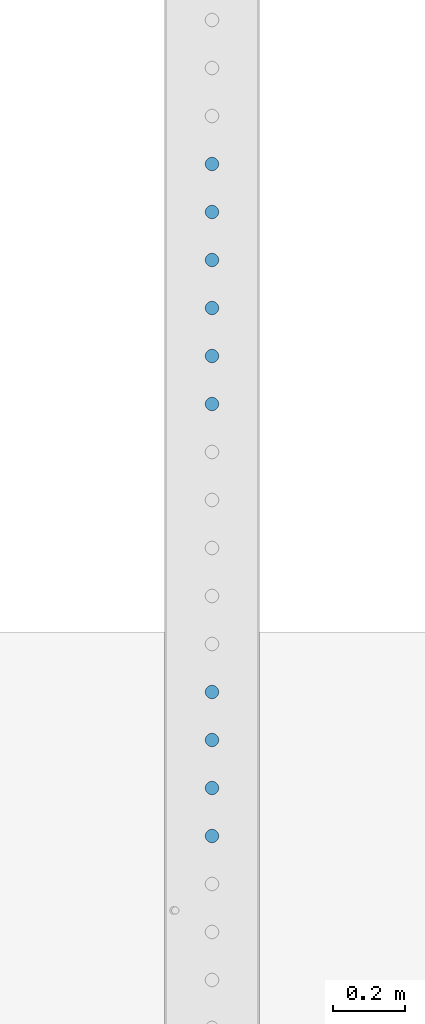
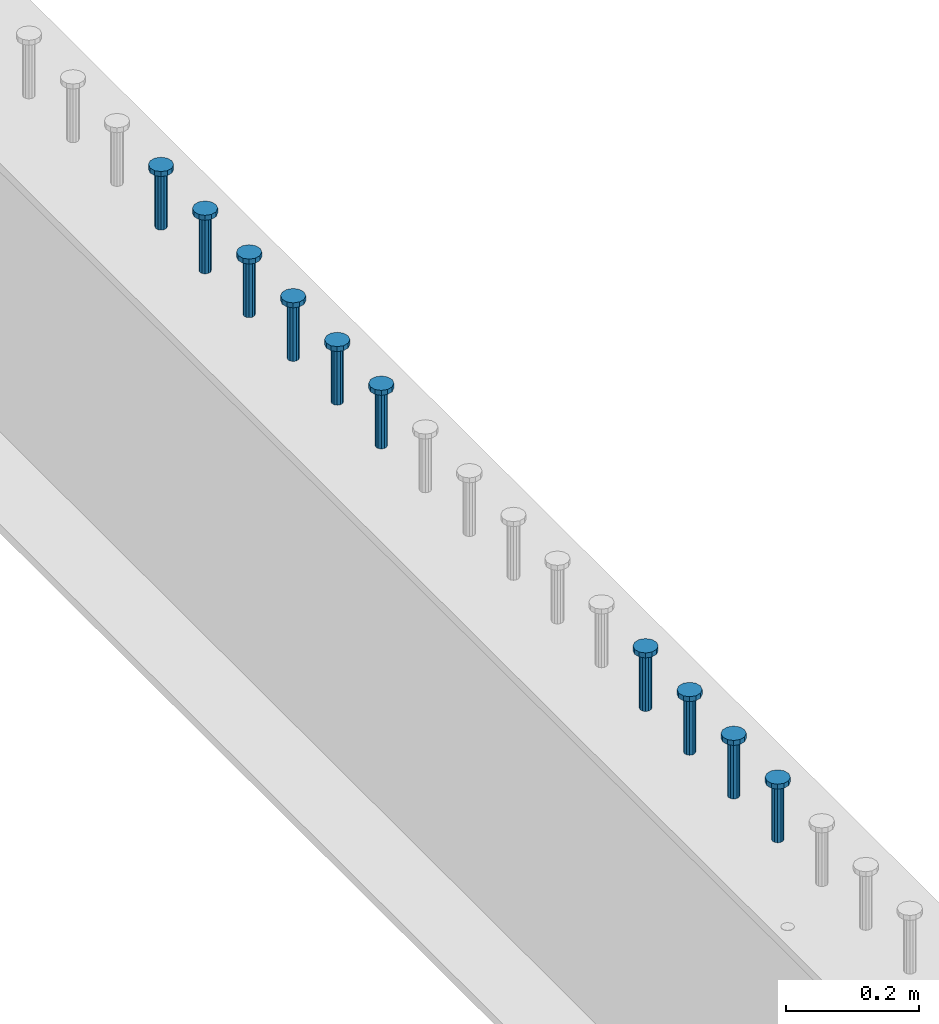
# One storey, part 941 of 1763: 10 columns, 10 elements without a shape of their own.
"""IFC2X3 building model written with IfcOpenShell, lengths in millimetres."""

from ifc_helpers import new_model, si_unit, frame, origin_with_axes, place, context, subcontext, project, spatial, faceted_brep, material, type_object, element, aggregate, save


model = new_model("IFC2X3")

# Units and contexts
model_context = context("Model", 3, precision=1e-05, world=origin_with_axes())
body_context = subcontext(model_context, "Body", "Model", "MODEL_VIEW")
ifc_project = project(units=[si_unit("LENGTHUNIT", "METRE", prefix="MILLI"), si_unit("AREAUNIT", "SQUARE_METRE"), si_unit("VOLUMEUNIT", "CUBIC_METRE"), si_unit("MASSUNIT", "GRAM", prefix="KILO"), si_unit("TIMEUNIT", "SECOND"), si_unit("PLANEANGLEUNIT", "RADIAN"), si_unit("SOLIDANGLEUNIT", "STERADIAN"), si_unit("THERMODYNAMICTEMPERATUREUNIT", "DEGREE_CELSIUS"), si_unit("LUMINOUSINTENSITYUNIT", "LUMEN")], contexts=[model_context])

# Site, building, storey
site_placement = place(None, origin_with_axes())
site = spatial("IfcSite", under=ifc_project, at=site_placement, CompositionType="ELEMENT")
building_placement = place(site_placement, origin_with_axes())
building = spatial("IfcBuilding", under=site, at=building_placement, Name="Undefined", CompositionType="ELEMENT")
storey_placement = place(building_placement, origin_with_axes())
storey = spatial("IfcBuildingStorey", under=building, at=storey_placement, Name="Undefined", CompositionType="ELEMENT", Elevation=0.0)

# Assembly, column
assembly_1_placement = place(storey_placement, origin_with_axes())
assembly_1 = element("IfcElementAssembly", 1, at=assembly_1_placement, inside=storey, Name="STUD", AssemblyPlace="NOTDEFINED", PredefinedType="RIGID_FRAME")
ifc_material = material(Name="STEEL/A108")
column_type = type_object("IfcColumnType", Name="STUD_3/4-DIA", PredefinedType="NOTDEFINED")
column_1_placement = place(assembly_1_placement, frame((-24027.8372736984, 32839.2145, 5194.3), z_axis=(-1.0, 0.0, 0.0), x_axis=(0.0, 0.0, 1.0)))
column_1 = element("IfcColumn", 2, at=column_1_placement, type_object=column_type, material=ifc_material, Name="STUD", ObjectType="STUD_3/4-DIA", context=body_context, shape_type="Brep", body=[
    faceted_brep([(0.0, -9.52000045776367, 0.0), (0.0, -8.25, -4.76000022888184), (104.013, -8.25, -4.76000022888184), (104.013, -9.52000045776367, 0.0), (0.0, -4.76000022888184, -8.25), (104.013, -4.76000022888184, -8.25), (0.0, 0.0, -9.52000045776367), (104.013, 0.0, -9.52000045776367), (0.0, 4.76000022888184, -8.25), (104.013, 4.76000022888184, -8.25), (0.0, 8.25, -4.76000022888184), (104.013, 8.25, -4.76000022888184), (0.0, 9.52000045776367, 0.0), (104.013, 9.52000045776367, 0.0), (0.0, 8.25, 4.76000022888184), (104.013, 8.25, 4.76000022888184), (0.0, 4.76000022888184, 8.25), (104.013, 4.76000022888184, 8.25), (0.0, 0.0, 9.52000045776367), (104.013, 0.0, 9.52000045776367), (0.0, -4.76000022888184, 8.25), (104.013, -4.76000022888184, 8.25), (0.0, -8.25, 4.76000022888184), (104.013, -8.25, 4.76000022888184), (105.156, -16.5, -9.52000045776367), (105.156, -19.0499992370605, 0.0), (105.156, -9.52000045776367, -16.5), (105.156, 0.0, -19.0499992370605), (105.156, 9.52000045776367, -16.5), (105.156, 16.5, -9.52000045776367), (105.156, 19.0499992370605, 0.0), (105.156, 16.5, 9.52000045776367), (105.156, 9.52000045776367, 16.5), (105.156, 0.0, 19.0499992370605), (105.156, -9.52000045776367, 16.5), (105.156, -16.5, 9.52000045776367), (114.3, -16.5, -9.52000045776367), (114.299998441489, -19.0500000000029, 0.0), (114.3, -9.52000045776367, -16.5), (114.3, 0.0, -19.0499992370605), (114.3, 9.52000045776367, -16.5), (114.3, 16.5, -9.52000045776367), (114.299998441489, 19.0500000000029, 0.0), (114.3, 16.5, 9.52000045776367), (114.3, 9.52000045776367, 16.5), (114.3, 0.0, 19.0499992370605), (114.3, -9.52000045776367, 16.5), (114.3, -16.5, 9.52000045776367)], [[[0, 1, 2, 3]], [[1, 4, 5, 2]], [[4, 6, 7, 5]], [[6, 8, 9, 7]], [[8, 10, 11, 9]], [[10, 12, 13, 11]], [[12, 14, 15, 13]], [[14, 16, 17, 15]], [[16, 18, 19, 17]], [[18, 20, 21, 19]], [[20, 22, 23, 21]], [[22, 0, 3, 23]], [[22, 20, 18, 16, 14, 12, 10, 8, 6, 4, 1, 0]], [[3, 2, 24, 25]], [[2, 5, 26, 24]], [[5, 7, 27, 26]], [[7, 9, 28, 27]], [[9, 11, 29, 28]], [[11, 13, 30, 29]], [[13, 15, 31, 30]], [[15, 17, 32, 31]], [[17, 19, 33, 32]], [[19, 21, 34, 33]], [[21, 23, 35, 34]], [[23, 3, 25, 35]], [[25, 24, 36, 37]], [[24, 26, 38, 36]], [[26, 27, 39, 38]], [[27, 28, 40, 39]], [[28, 29, 41, 40]], [[29, 30, 42, 41]], [[30, 31, 43, 42]], [[31, 32, 44, 43]], [[32, 33, 45, 44]], [[33, 34, 46, 45]], [[34, 35, 47, 46]], [[35, 25, 37, 47]], [[38, 39, 40, 41, 42, 43, 44, 45, 46, 47, 37, 36]]]),
])
aggregate(assembly_1, [column_1])

assembly_2_placement = place(storey_placement, origin_with_axes())
assembly_2 = element("IfcElementAssembly", 3, at=assembly_2_placement, inside=storey, Name="STUD", AssemblyPlace="NOTDEFINED", PredefinedType="RIGID_FRAME")
column_2_placement = place(assembly_2_placement, frame((-24027.8372736984, 32706.6065, 5194.3), z_axis=(-1.0, 0.0, 0.0), x_axis=(0.0, 0.0, 1.0)))
column_2 = element("IfcColumn", 4, at=column_2_placement, type_object=column_type, material=ifc_material, Name="STUD", ObjectType="STUD_3/4-DIA", context=body_context, shape_type="Brep", body=[
    faceted_brep([(0.0, -9.52000045776367, 0.0), (0.0, -8.25, -4.76000022888184), (104.013, -8.25, -4.76000022888184), (104.013, -9.52000045776367, 0.0), (0.0, -4.76000022888184, -8.25), (104.013, -4.76000022888184, -8.25), (0.0, 0.0, -9.52000045776367), (104.013, 0.0, -9.52000045776367), (0.0, 4.76000022888184, -8.25), (104.013, 4.76000022888184, -8.25), (0.0, 8.25, -4.76000022888184), (104.013, 8.25, -4.76000022888184), (0.0, 9.52000045776367, 0.0), (104.013, 9.52000045776367, 0.0), (0.0, 8.25, 4.76000022888184), (104.013, 8.25, 4.76000022888184), (0.0, 4.76000022888184, 8.25), (104.013, 4.76000022888184, 8.25), (0.0, 0.0, 9.52000045776367), (104.013, 0.0, 9.52000045776367), (0.0, -4.76000022888184, 8.25), (104.013, -4.76000022888184, 8.25), (0.0, -8.25, 4.76000022888184), (104.013, -8.25, 4.76000022888184), (105.156, -16.5, -9.52000045776367), (105.156, -19.0499992370605, 0.0), (105.156, -9.52000045776367, -16.5), (105.156, 0.0, -19.0499992370605), (105.156, 9.52000045776367, -16.5), (105.156, 16.5, -9.52000045776367), (105.156, 19.0499992370605, 0.0), (105.156, 16.5, 9.52000045776367), (105.156, 9.52000045776367, 16.5), (105.156, 0.0, 19.0499992370605), (105.156, -9.52000045776367, 16.5), (105.156, -16.5, 9.52000045776367), (114.3, -16.5, -9.52000045776367), (114.299998441489, -19.0500000000029, 0.0), (114.3, -9.52000045776367, -16.5), (114.3, 0.0, -19.0499992370605), (114.3, 9.52000045776367, -16.5), (114.3, 16.5, -9.52000045776367), (114.299998441489, 19.0500000000029, 0.0), (114.3, 16.5, 9.52000045776367), (114.3, 9.52000045776367, 16.5), (114.3, 0.0, 19.0499992370605), (114.3, -9.52000045776367, 16.5), (114.3, -16.5, 9.52000045776367)], [[[0, 1, 2, 3]], [[1, 4, 5, 2]], [[4, 6, 7, 5]], [[6, 8, 9, 7]], [[8, 10, 11, 9]], [[10, 12, 13, 11]], [[12, 14, 15, 13]], [[14, 16, 17, 15]], [[16, 18, 19, 17]], [[18, 20, 21, 19]], [[20, 22, 23, 21]], [[22, 0, 3, 23]], [[22, 20, 18, 16, 14, 12, 10, 8, 6, 4, 1, 0]], [[3, 2, 24, 25]], [[2, 5, 26, 24]], [[5, 7, 27, 26]], [[7, 9, 28, 27]], [[9, 11, 29, 28]], [[11, 13, 30, 29]], [[13, 15, 31, 30]], [[15, 17, 32, 31]], [[17, 19, 33, 32]], [[19, 21, 34, 33]], [[21, 23, 35, 34]], [[23, 3, 25, 35]], [[25, 24, 36, 37]], [[24, 26, 38, 36]], [[26, 27, 39, 38]], [[27, 28, 40, 39]], [[28, 29, 41, 40]], [[29, 30, 42, 41]], [[30, 31, 43, 42]], [[31, 32, 44, 43]], [[32, 33, 45, 44]], [[33, 34, 46, 45]], [[34, 35, 47, 46]], [[35, 25, 37, 47]], [[38, 39, 40, 41, 42, 43, 44, 45, 46, 47, 37, 36]]]),
])
aggregate(assembly_2, [column_2])

assembly_3_placement = place(storey_placement, origin_with_axes())
assembly_3 = element("IfcElementAssembly", 5, at=assembly_3_placement, inside=storey, Name="STUD", AssemblyPlace="NOTDEFINED", PredefinedType="RIGID_FRAME")
column_3_placement = place(assembly_3_placement, frame((-24027.8372736984, 32573.9985, 5194.3), z_axis=(-1.0, 0.0, 0.0), x_axis=(0.0, 0.0, 1.0)))
column_3 = element("IfcColumn", 6, at=column_3_placement, type_object=column_type, material=ifc_material, Name="STUD", ObjectType="STUD_3/4-DIA", context=body_context, shape_type="Brep", body=[
    faceted_brep([(0.0, -9.52000045776367, 0.0), (0.0, -8.25, -4.76000022888184), (104.013, -8.25, -4.76000022888184), (104.013, -9.52000045776367, 0.0), (0.0, -4.76000022888184, -8.25), (104.013, -4.76000022888184, -8.25), (0.0, 0.0, -9.52000045776367), (104.013, 0.0, -9.52000045776367), (0.0, 4.76000022888184, -8.25), (104.013, 4.76000022888184, -8.25), (0.0, 8.25, -4.76000022888184), (104.013, 8.25, -4.76000022888184), (0.0, 9.52000045776367, 0.0), (104.013, 9.52000045776367, 0.0), (0.0, 8.25, 4.76000022888184), (104.013, 8.25, 4.76000022888184), (0.0, 4.76000022888184, 8.25), (104.013, 4.76000022888184, 8.25), (0.0, 0.0, 9.52000045776367), (104.013, 0.0, 9.52000045776367), (0.0, -4.76000022888184, 8.25), (104.013, -4.76000022888184, 8.25), (0.0, -8.25, 4.76000022888184), (104.013, -8.25, 4.76000022888184), (105.156, -16.5, -9.52000045776367), (105.156, -19.0499992370605, 0.0), (105.156, -9.52000045776367, -16.5), (105.156, 0.0, -19.0499992370605), (105.156, 9.52000045776367, -16.5), (105.156, 16.5, -9.52000045776367), (105.156, 19.0499992370605, 0.0), (105.156, 16.5, 9.52000045776367), (105.156, 9.52000045776367, 16.5), (105.156, 0.0, 19.0499992370605), (105.156, -9.52000045776367, 16.5), (105.156, -16.5, 9.52000045776367), (114.3, -16.5, -9.52000045776367), (114.299998441489, -19.0500000000029, 0.0), (114.3, -9.52000045776367, -16.5), (114.3, 0.0, -19.0499992370605), (114.3, 9.52000045776367, -16.5), (114.3, 16.5, -9.52000045776367), (114.299998441489, 19.0500000000029, 0.0), (114.3, 16.5, 9.52000045776367), (114.3, 9.52000045776367, 16.5), (114.3, 0.0, 19.0499992370605), (114.3, -9.52000045776367, 16.5), (114.3, -16.5, 9.52000045776367)], [[[0, 1, 2, 3]], [[1, 4, 5, 2]], [[4, 6, 7, 5]], [[6, 8, 9, 7]], [[8, 10, 11, 9]], [[10, 12, 13, 11]], [[12, 14, 15, 13]], [[14, 16, 17, 15]], [[16, 18, 19, 17]], [[18, 20, 21, 19]], [[20, 22, 23, 21]], [[22, 0, 3, 23]], [[22, 20, 18, 16, 14, 12, 10, 8, 6, 4, 1, 0]], [[3, 2, 24, 25]], [[2, 5, 26, 24]], [[5, 7, 27, 26]], [[7, 9, 28, 27]], [[9, 11, 29, 28]], [[11, 13, 30, 29]], [[13, 15, 31, 30]], [[15, 17, 32, 31]], [[17, 19, 33, 32]], [[19, 21, 34, 33]], [[21, 23, 35, 34]], [[23, 3, 25, 35]], [[25, 24, 36, 37]], [[24, 26, 38, 36]], [[26, 27, 39, 38]], [[27, 28, 40, 39]], [[28, 29, 41, 40]], [[29, 30, 42, 41]], [[30, 31, 43, 42]], [[31, 32, 44, 43]], [[32, 33, 45, 44]], [[33, 34, 46, 45]], [[34, 35, 47, 46]], [[35, 25, 37, 47]], [[38, 39, 40, 41, 42, 43, 44, 45, 46, 47, 37, 36]]]),
])
aggregate(assembly_3, [column_3])

assembly_4_placement = place(storey_placement, origin_with_axes())
assembly_4 = element("IfcElementAssembly", 7, at=assembly_4_placement, inside=storey, Name="STUD", AssemblyPlace="NOTDEFINED", PredefinedType="RIGID_FRAME")
column_4_placement = place(assembly_4_placement, frame((-24027.8372736984, 32441.3905, 5194.3), z_axis=(-1.0, 0.0, 0.0), x_axis=(0.0, 0.0, 1.0)))
column_4 = element("IfcColumn", 8, at=column_4_placement, type_object=column_type, material=ifc_material, Name="STUD", ObjectType="STUD_3/4-DIA", context=body_context, shape_type="Brep", body=[
    faceted_brep([(0.0, -9.52000045776367, 0.0), (0.0, -8.25, -4.76000022888184), (104.013, -8.25, -4.76000022888184), (104.013, -9.52000045776367, 0.0), (0.0, -4.76000022888184, -8.25), (104.013, -4.76000022888184, -8.25), (0.0, 0.0, -9.52000045776367), (104.013, 0.0, -9.52000045776367), (0.0, 4.76000022888184, -8.25), (104.013, 4.76000022888184, -8.25), (0.0, 8.25, -4.76000022888184), (104.013, 8.25, -4.76000022888184), (0.0, 9.52000045776367, 0.0), (104.013, 9.52000045776367, 0.0), (0.0, 8.25, 4.76000022888184), (104.013, 8.25, 4.76000022888184), (0.0, 4.76000022888184, 8.25), (104.013, 4.76000022888184, 8.25), (0.0, 0.0, 9.52000045776367), (104.013, 0.0, 9.52000045776367), (0.0, -4.76000022888184, 8.25), (104.013, -4.76000022888184, 8.25), (0.0, -8.25, 4.76000022888184), (104.013, -8.25, 4.76000022888184), (105.156, -16.5, -9.52000045776367), (105.156, -19.0499992370605, 0.0), (105.156, -9.52000045776367, -16.5), (105.156, 0.0, -19.0499992370605), (105.156, 9.52000045776367, -16.5), (105.156, 16.5, -9.52000045776367), (105.156, 19.0499992370605, 0.0), (105.156, 16.5, 9.52000045776367), (105.156, 9.52000045776367, 16.5), (105.156, 0.0, 19.0499992370605), (105.156, -9.52000045776367, 16.5), (105.156, -16.5, 9.52000045776367), (114.3, -16.5, -9.52000045776367), (114.299998441489, -19.0500000000029, 0.0), (114.3, -9.52000045776367, -16.5), (114.3, 0.0, -19.0499992370605), (114.3, 9.52000045776367, -16.5), (114.3, 16.5, -9.52000045776367), (114.299998441489, 19.0500000000029, 0.0), (114.3, 16.5, 9.52000045776367), (114.3, 9.52000045776367, 16.5), (114.3, 0.0, 19.0499992370605), (114.3, -9.52000045776367, 16.5), (114.3, -16.5, 9.52000045776367)], [[[0, 1, 2, 3]], [[1, 4, 5, 2]], [[4, 6, 7, 5]], [[6, 8, 9, 7]], [[8, 10, 11, 9]], [[10, 12, 13, 11]], [[12, 14, 15, 13]], [[14, 16, 17, 15]], [[16, 18, 19, 17]], [[18, 20, 21, 19]], [[20, 22, 23, 21]], [[22, 0, 3, 23]], [[22, 20, 18, 16, 14, 12, 10, 8, 6, 4, 1, 0]], [[3, 2, 24, 25]], [[2, 5, 26, 24]], [[5, 7, 27, 26]], [[7, 9, 28, 27]], [[9, 11, 29, 28]], [[11, 13, 30, 29]], [[13, 15, 31, 30]], [[15, 17, 32, 31]], [[17, 19, 33, 32]], [[19, 21, 34, 33]], [[21, 23, 35, 34]], [[23, 3, 25, 35]], [[25, 24, 36, 37]], [[24, 26, 38, 36]], [[26, 27, 39, 38]], [[27, 28, 40, 39]], [[28, 29, 41, 40]], [[29, 30, 42, 41]], [[30, 31, 43, 42]], [[31, 32, 44, 43]], [[32, 33, 45, 44]], [[33, 34, 46, 45]], [[34, 35, 47, 46]], [[35, 25, 37, 47]], [[38, 39, 40, 41, 42, 43, 44, 45, 46, 47, 37, 36]]]),
])
aggregate(assembly_4, [column_4])

assembly_5_placement = place(storey_placement, origin_with_axes())
assembly_5 = element("IfcElementAssembly", 9, at=assembly_5_placement, inside=storey, Name="STUD", AssemblyPlace="NOTDEFINED", PredefinedType="RIGID_FRAME")
column_5_placement = place(assembly_5_placement, frame((-24027.8372736984, 32308.7825, 5194.3), z_axis=(-1.0, 0.0, 0.0), x_axis=(0.0, 0.0, 1.0)))
column_5 = element("IfcColumn", 10, at=column_5_placement, type_object=column_type, material=ifc_material, Name="STUD", ObjectType="STUD_3/4-DIA", context=body_context, shape_type="Brep", body=[
    faceted_brep([(0.0, -9.52000045776367, 0.0), (0.0, -8.25, -4.76000022888184), (104.013, -8.25, -4.76000022888184), (104.013, -9.52000045776367, 0.0), (0.0, -4.76000022888184, -8.25), (104.013, -4.76000022888184, -8.25), (0.0, 0.0, -9.52000045776367), (104.013, 0.0, -9.52000045776367), (0.0, 4.76000022888184, -8.25), (104.013, 4.76000022888184, -8.25), (0.0, 8.25, -4.76000022888184), (104.013, 8.25, -4.76000022888184), (0.0, 9.52000045776367, 0.0), (104.013, 9.52000045776367, 0.0), (0.0, 8.25, 4.76000022888184), (104.013, 8.25, 4.76000022888184), (0.0, 4.76000022888184, 8.25), (104.013, 4.76000022888184, 8.25), (0.0, 0.0, 9.52000045776367), (104.013, 0.0, 9.52000045776367), (0.0, -4.76000022888184, 8.25), (104.013, -4.76000022888184, 8.25), (0.0, -8.25, 4.76000022888184), (104.013, -8.25, 4.76000022888184), (105.156, -16.5, -9.52000045776367), (105.156, -19.0499992370605, 0.0), (105.156, -9.52000045776367, -16.5), (105.156, 0.0, -19.0499992370605), (105.156, 9.52000045776367, -16.5), (105.156, 16.5, -9.52000045776367), (105.156, 19.0499992370605, 0.0), (105.156, 16.5, 9.52000045776367), (105.156, 9.52000045776367, 16.5), (105.156, 0.0, 19.0499992370605), (105.156, -9.52000045776367, 16.5), (105.156, -16.5, 9.52000045776367), (114.3, -16.5, -9.52000045776367), (114.299998441489, -19.0500000000029, 0.0), (114.3, -9.52000045776367, -16.5), (114.3, 0.0, -19.0499992370605), (114.3, 9.52000045776367, -16.5), (114.3, 16.5, -9.52000045776367), (114.299998441489, 19.0500000000029, 0.0), (114.3, 16.5, 9.52000045776367), (114.3, 9.52000045776367, 16.5), (114.3, 0.0, 19.0499992370605), (114.3, -9.52000045776367, 16.5), (114.3, -16.5, 9.52000045776367)], [[[0, 1, 2, 3]], [[1, 4, 5, 2]], [[4, 6, 7, 5]], [[6, 8, 9, 7]], [[8, 10, 11, 9]], [[10, 12, 13, 11]], [[12, 14, 15, 13]], [[14, 16, 17, 15]], [[16, 18, 19, 17]], [[18, 20, 21, 19]], [[20, 22, 23, 21]], [[22, 0, 3, 23]], [[22, 20, 18, 16, 14, 12, 10, 8, 6, 4, 1, 0]], [[3, 2, 24, 25]], [[2, 5, 26, 24]], [[5, 7, 27, 26]], [[7, 9, 28, 27]], [[9, 11, 29, 28]], [[11, 13, 30, 29]], [[13, 15, 31, 30]], [[15, 17, 32, 31]], [[17, 19, 33, 32]], [[19, 21, 34, 33]], [[21, 23, 35, 34]], [[23, 3, 25, 35]], [[25, 24, 36, 37]], [[24, 26, 38, 36]], [[26, 27, 39, 38]], [[27, 28, 40, 39]], [[28, 29, 41, 40]], [[29, 30, 42, 41]], [[30, 31, 43, 42]], [[31, 32, 44, 43]], [[32, 33, 45, 44]], [[33, 34, 46, 45]], [[34, 35, 47, 46]], [[35, 25, 37, 47]], [[38, 39, 40, 41, 42, 43, 44, 45, 46, 47, 37, 36]]]),
])
aggregate(assembly_5, [column_5])

assembly_6_placement = place(storey_placement, origin_with_axes())
assembly_6 = element("IfcElementAssembly", 11, at=assembly_6_placement, inside=storey, Name="STUD", AssemblyPlace="NOTDEFINED", PredefinedType="RIGID_FRAME")
column_6_placement = place(assembly_6_placement, frame((-24027.8372736984, 32176.1745, 5194.3), z_axis=(-1.0, 0.0, 0.0), x_axis=(0.0, 0.0, 1.0)))
column_6 = element("IfcColumn", 12, at=column_6_placement, type_object=column_type, material=ifc_material, Name="STUD", ObjectType="STUD_3/4-DIA", context=body_context, shape_type="Brep", body=[
    faceted_brep([(0.0, -9.52000045776367, 0.0), (0.0, -8.25, -4.76000022888184), (104.013, -8.25, -4.76000022888184), (104.013, -9.52000045776367, 0.0), (0.0, -4.76000022888184, -8.25), (104.013, -4.76000022888184, -8.25), (0.0, 0.0, -9.52000045776367), (104.013, 0.0, -9.52000045776367), (0.0, 4.76000022888184, -8.25), (104.013, 4.76000022888184, -8.25), (0.0, 8.25, -4.76000022888184), (104.013, 8.25, -4.76000022888184), (0.0, 9.52000045776367, 0.0), (104.013, 9.52000045776367, 0.0), (0.0, 8.25, 4.76000022888184), (104.013, 8.25, 4.76000022888184), (0.0, 4.76000022888184, 8.25), (104.013, 4.76000022888184, 8.25), (0.0, 0.0, 9.52000045776367), (104.013, 0.0, 9.52000045776367), (0.0, -4.76000022888184, 8.25), (104.013, -4.76000022888184, 8.25), (0.0, -8.25, 4.76000022888184), (104.013, -8.25, 4.76000022888184), (105.156, -16.5, -9.52000045776367), (105.156, -19.0499992370605, 0.0), (105.156, -9.52000045776367, -16.5), (105.156, 0.0, -19.0499992370605), (105.156, 9.52000045776367, -16.5), (105.156, 16.5, -9.52000045776367), (105.156, 19.0499992370605, 0.0), (105.156, 16.5, 9.52000045776367), (105.156, 9.52000045776367, 16.5), (105.156, 0.0, 19.0499992370605), (105.156, -9.52000045776367, 16.5), (105.156, -16.5, 9.52000045776367), (114.3, -16.5, -9.52000045776367), (114.299998441489, -19.0500000000029, 0.0), (114.3, -9.52000045776367, -16.5), (114.3, 0.0, -19.0499992370605), (114.3, 9.52000045776367, -16.5), (114.3, 16.5, -9.52000045776367), (114.299998441489, 19.0500000000029, 0.0), (114.3, 16.5, 9.52000045776367), (114.3, 9.52000045776367, 16.5), (114.3, 0.0, 19.0499992370605), (114.3, -9.52000045776367, 16.5), (114.3, -16.5, 9.52000045776367)], [[[0, 1, 2, 3]], [[1, 4, 5, 2]], [[4, 6, 7, 5]], [[6, 8, 9, 7]], [[8, 10, 11, 9]], [[10, 12, 13, 11]], [[12, 14, 15, 13]], [[14, 16, 17, 15]], [[16, 18, 19, 17]], [[18, 20, 21, 19]], [[20, 22, 23, 21]], [[22, 0, 3, 23]], [[22, 20, 18, 16, 14, 12, 10, 8, 6, 4, 1, 0]], [[3, 2, 24, 25]], [[2, 5, 26, 24]], [[5, 7, 27, 26]], [[7, 9, 28, 27]], [[9, 11, 29, 28]], [[11, 13, 30, 29]], [[13, 15, 31, 30]], [[15, 17, 32, 31]], [[17, 19, 33, 32]], [[19, 21, 34, 33]], [[21, 23, 35, 34]], [[23, 3, 25, 35]], [[25, 24, 36, 37]], [[24, 26, 38, 36]], [[26, 27, 39, 38]], [[27, 28, 40, 39]], [[28, 29, 41, 40]], [[29, 30, 42, 41]], [[30, 31, 43, 42]], [[31, 32, 44, 43]], [[32, 33, 45, 44]], [[33, 34, 46, 45]], [[34, 35, 47, 46]], [[35, 25, 37, 47]], [[38, 39, 40, 41, 42, 43, 44, 45, 46, 47, 37, 36]]]),
])
aggregate(assembly_6, [column_6])

assembly_7_placement = place(storey_placement, origin_with_axes())
assembly_7 = element("IfcElementAssembly", 13, at=assembly_7_placement, inside=storey, Name="STUD", AssemblyPlace="NOTDEFINED", PredefinedType="RIGID_FRAME")
column_7_placement = place(assembly_7_placement, frame((-24027.8372736984, 31380.5265, 5194.3), z_axis=(-1.0, 0.0, 0.0), x_axis=(0.0, 0.0, 1.0)))
column_7 = element("IfcColumn", 14, at=column_7_placement, type_object=column_type, material=ifc_material, Name="STUD", ObjectType="STUD_3/4-DIA", context=body_context, shape_type="Brep", body=[
    faceted_brep([(0.0, -9.52000045776367, 0.0), (0.0, -8.25, -4.76000022888184), (104.013, -8.25, -4.76000022888184), (104.013, -9.52000045776367, 0.0), (0.0, -4.76000022888184, -8.25), (104.013, -4.76000022888184, -8.25), (0.0, 0.0, -9.52000045776367), (104.013, 0.0, -9.52000045776367), (0.0, 4.76000022888184, -8.25), (104.013, 4.76000022888184, -8.25), (0.0, 8.25, -4.76000022888184), (104.013, 8.25, -4.76000022888184), (0.0, 9.52000045776367, 0.0), (104.013, 9.52000045776367, 0.0), (0.0, 8.25, 4.76000022888184), (104.013, 8.25, 4.76000022888184), (0.0, 4.76000022888184, 8.25), (104.013, 4.76000022888184, 8.25), (0.0, 0.0, 9.52000045776367), (104.013, 0.0, 9.52000045776367), (0.0, -4.76000022888184, 8.25), (104.013, -4.76000022888184, 8.25), (0.0, -8.25, 4.76000022888184), (104.013, -8.25, 4.76000022888184), (105.156, -16.5, -9.52000045776367), (105.156, -19.0499992370605, 0.0), (105.156, -9.52000045776367, -16.5), (105.156, 0.0, -19.0499992370605), (105.156, 9.52000045776367, -16.5), (105.156, 16.5, -9.52000045776367), (105.156, 19.0499992370605, 0.0), (105.156, 16.5, 9.52000045776367), (105.156, 9.52000045776367, 16.5), (105.156, 0.0, 19.0499992370605), (105.156, -9.52000045776367, 16.5), (105.156, -16.5, 9.52000045776367), (114.3, -16.5, -9.52000045776367), (114.299998441489, -19.0500000000029, 0.0), (114.3, -9.52000045776367, -16.5), (114.3, 0.0, -19.0499992370605), (114.3, 9.52000045776367, -16.5), (114.3, 16.5, -9.52000045776367), (114.299998441489, 19.0500000000029, 0.0), (114.3, 16.5, 9.52000045776367), (114.3, 9.52000045776367, 16.5), (114.3, 0.0, 19.0499992370605), (114.3, -9.52000045776367, 16.5), (114.3, -16.5, 9.52000045776367)], [[[0, 1, 2, 3]], [[1, 4, 5, 2]], [[4, 6, 7, 5]], [[6, 8, 9, 7]], [[8, 10, 11, 9]], [[10, 12, 13, 11]], [[12, 14, 15, 13]], [[14, 16, 17, 15]], [[16, 18, 19, 17]], [[18, 20, 21, 19]], [[20, 22, 23, 21]], [[22, 0, 3, 23]], [[22, 20, 18, 16, 14, 12, 10, 8, 6, 4, 1, 0]], [[3, 2, 24, 25]], [[2, 5, 26, 24]], [[5, 7, 27, 26]], [[7, 9, 28, 27]], [[9, 11, 29, 28]], [[11, 13, 30, 29]], [[13, 15, 31, 30]], [[15, 17, 32, 31]], [[17, 19, 33, 32]], [[19, 21, 34, 33]], [[21, 23, 35, 34]], [[23, 3, 25, 35]], [[25, 24, 36, 37]], [[24, 26, 38, 36]], [[26, 27, 39, 38]], [[27, 28, 40, 39]], [[28, 29, 41, 40]], [[29, 30, 42, 41]], [[30, 31, 43, 42]], [[31, 32, 44, 43]], [[32, 33, 45, 44]], [[33, 34, 46, 45]], [[34, 35, 47, 46]], [[35, 25, 37, 47]], [[38, 39, 40, 41, 42, 43, 44, 45, 46, 47, 37, 36]]]),
])
aggregate(assembly_7, [column_7])

assembly_8_placement = place(storey_placement, origin_with_axes())
assembly_8 = element("IfcElementAssembly", 15, at=assembly_8_placement, inside=storey, Name="STUD", AssemblyPlace="NOTDEFINED", PredefinedType="RIGID_FRAME")
column_8_placement = place(assembly_8_placement, frame((-24027.8372736984, 31247.9185, 5194.3), z_axis=(-1.0, 0.0, 0.0), x_axis=(0.0, 0.0, 1.0)))
column_8 = element("IfcColumn", 16, at=column_8_placement, type_object=column_type, material=ifc_material, Name="STUD", ObjectType="STUD_3/4-DIA", context=body_context, shape_type="Brep", body=[
    faceted_brep([(0.0, -9.52000045776367, 0.0), (0.0, -8.25, -4.76000022888184), (104.013, -8.25, -4.76000022888184), (104.013, -9.52000045776367, 0.0), (0.0, -4.76000022888184, -8.25), (104.013, -4.76000022888184, -8.25), (0.0, 0.0, -9.52000045776367), (104.013, 0.0, -9.52000045776367), (0.0, 4.76000022888184, -8.25), (104.013, 4.76000022888184, -8.25), (0.0, 8.25, -4.76000022888184), (104.013, 8.25, -4.76000022888184), (0.0, 9.52000045776367, 0.0), (104.013, 9.52000045776367, 0.0), (0.0, 8.25, 4.76000022888184), (104.013, 8.25, 4.76000022888184), (0.0, 4.76000022888184, 8.25), (104.013, 4.76000022888184, 8.25), (0.0, 0.0, 9.52000045776367), (104.013, 0.0, 9.52000045776367), (0.0, -4.76000022888184, 8.25), (104.013, -4.76000022888184, 8.25), (0.0, -8.25, 4.76000022888184), (104.013, -8.25, 4.76000022888184), (105.156, -16.5, -9.52000045776367), (105.156, -19.0499992370605, 0.0), (105.156, -9.52000045776367, -16.5), (105.156, 0.0, -19.0499992370605), (105.156, 9.52000045776367, -16.5), (105.156, 16.5, -9.52000045776367), (105.156, 19.0499992370605, 0.0), (105.156, 16.5, 9.52000045776367), (105.156, 9.52000045776367, 16.5), (105.156, 0.0, 19.0499992370605), (105.156, -9.52000045776367, 16.5), (105.156, -16.5, 9.52000045776367), (114.3, -16.5, -9.52000045776367), (114.299998441489, -19.0500000000029, 0.0), (114.3, -9.52000045776367, -16.5), (114.3, 0.0, -19.0499992370605), (114.3, 9.52000045776367, -16.5), (114.3, 16.5, -9.52000045776367), (114.299998441489, 19.0500000000029, 0.0), (114.3, 16.5, 9.52000045776367), (114.3, 9.52000045776367, 16.5), (114.3, 0.0, 19.0499992370605), (114.3, -9.52000045776367, 16.5), (114.3, -16.5, 9.52000045776367)], [[[0, 1, 2, 3]], [[1, 4, 5, 2]], [[4, 6, 7, 5]], [[6, 8, 9, 7]], [[8, 10, 11, 9]], [[10, 12, 13, 11]], [[12, 14, 15, 13]], [[14, 16, 17, 15]], [[16, 18, 19, 17]], [[18, 20, 21, 19]], [[20, 22, 23, 21]], [[22, 0, 3, 23]], [[22, 20, 18, 16, 14, 12, 10, 8, 6, 4, 1, 0]], [[3, 2, 24, 25]], [[2, 5, 26, 24]], [[5, 7, 27, 26]], [[7, 9, 28, 27]], [[9, 11, 29, 28]], [[11, 13, 30, 29]], [[13, 15, 31, 30]], [[15, 17, 32, 31]], [[17, 19, 33, 32]], [[19, 21, 34, 33]], [[21, 23, 35, 34]], [[23, 3, 25, 35]], [[25, 24, 36, 37]], [[24, 26, 38, 36]], [[26, 27, 39, 38]], [[27, 28, 40, 39]], [[28, 29, 41, 40]], [[29, 30, 42, 41]], [[30, 31, 43, 42]], [[31, 32, 44, 43]], [[32, 33, 45, 44]], [[33, 34, 46, 45]], [[34, 35, 47, 46]], [[35, 25, 37, 47]], [[38, 39, 40, 41, 42, 43, 44, 45, 46, 47, 37, 36]]]),
])
aggregate(assembly_8, [column_8])

assembly_9_placement = place(storey_placement, origin_with_axes())
assembly_9 = element("IfcElementAssembly", 17, at=assembly_9_placement, inside=storey, Name="STUD", AssemblyPlace="NOTDEFINED", PredefinedType="RIGID_FRAME")
column_9_placement = place(assembly_9_placement, frame((-24027.8372736984, 31115.3105, 5194.3), z_axis=(-1.0, 0.0, 0.0), x_axis=(0.0, 0.0, 1.0)))
column_9 = element("IfcColumn", 18, at=column_9_placement, type_object=column_type, material=ifc_material, Name="STUD", ObjectType="STUD_3/4-DIA", context=body_context, shape_type="Brep", body=[
    faceted_brep([(0.0, -9.52000045776367, 0.0), (0.0, -8.25, -4.76000022888184), (104.013, -8.25, -4.76000022888184), (104.013, -9.52000045776367, 0.0), (0.0, -4.76000022888184, -8.25), (104.013, -4.76000022888184, -8.25), (0.0, 0.0, -9.52000045776367), (104.013, 0.0, -9.52000045776367), (0.0, 4.76000022888184, -8.25), (104.013, 4.76000022888184, -8.25), (0.0, 8.25, -4.76000022888184), (104.013, 8.25, -4.76000022888184), (0.0, 9.52000045776367, 0.0), (104.013, 9.52000045776367, 0.0), (0.0, 8.25, 4.76000022888184), (104.013, 8.25, 4.76000022888184), (0.0, 4.76000022888184, 8.25), (104.013, 4.76000022888184, 8.25), (0.0, 0.0, 9.52000045776367), (104.013, 0.0, 9.52000045776367), (0.0, -4.76000022888184, 8.25), (104.013, -4.76000022888184, 8.25), (0.0, -8.25, 4.76000022888184), (104.013, -8.25, 4.76000022888184), (105.156, -16.5, -9.52000045776367), (105.156, -19.0499992370605, 0.0), (105.156, -9.52000045776367, -16.5), (105.156, 0.0, -19.0499992370605), (105.156, 9.52000045776367, -16.5), (105.156, 16.5, -9.52000045776367), (105.156, 19.0499992370605, 0.0), (105.156, 16.5, 9.52000045776367), (105.156, 9.52000045776367, 16.5), (105.156, 0.0, 19.0499992370605), (105.156, -9.52000045776367, 16.5), (105.156, -16.5, 9.52000045776367), (114.3, -16.5, -9.52000045776367), (114.299998441489, -19.0500000000029, 0.0), (114.3, -9.52000045776367, -16.5), (114.3, 0.0, -19.0499992370605), (114.3, 9.52000045776367, -16.5), (114.3, 16.5, -9.52000045776367), (114.299998441489, 19.0500000000029, 0.0), (114.3, 16.5, 9.52000045776367), (114.3, 9.52000045776367, 16.5), (114.3, 0.0, 19.0499992370605), (114.3, -9.52000045776367, 16.5), (114.3, -16.5, 9.52000045776367)], [[[0, 1, 2, 3]], [[1, 4, 5, 2]], [[4, 6, 7, 5]], [[6, 8, 9, 7]], [[8, 10, 11, 9]], [[10, 12, 13, 11]], [[12, 14, 15, 13]], [[14, 16, 17, 15]], [[16, 18, 19, 17]], [[18, 20, 21, 19]], [[20, 22, 23, 21]], [[22, 0, 3, 23]], [[22, 20, 18, 16, 14, 12, 10, 8, 6, 4, 1, 0]], [[3, 2, 24, 25]], [[2, 5, 26, 24]], [[5, 7, 27, 26]], [[7, 9, 28, 27]], [[9, 11, 29, 28]], [[11, 13, 30, 29]], [[13, 15, 31, 30]], [[15, 17, 32, 31]], [[17, 19, 33, 32]], [[19, 21, 34, 33]], [[21, 23, 35, 34]], [[23, 3, 25, 35]], [[25, 24, 36, 37]], [[24, 26, 38, 36]], [[26, 27, 39, 38]], [[27, 28, 40, 39]], [[28, 29, 41, 40]], [[29, 30, 42, 41]], [[30, 31, 43, 42]], [[31, 32, 44, 43]], [[32, 33, 45, 44]], [[33, 34, 46, 45]], [[34, 35, 47, 46]], [[35, 25, 37, 47]], [[38, 39, 40, 41, 42, 43, 44, 45, 46, 47, 37, 36]]]),
])
aggregate(assembly_9, [column_9])

assembly_10_placement = place(storey_placement, origin_with_axes())
assembly_10 = element("IfcElementAssembly", 19, at=assembly_10_placement, inside=storey, Name="STUD", AssemblyPlace="NOTDEFINED", PredefinedType="RIGID_FRAME")
column_10_placement = place(assembly_10_placement, frame((-24027.8372736984, 30982.7025, 5194.3), z_axis=(-1.0, 0.0, 0.0), x_axis=(0.0, 0.0, 1.0)))
column_10 = element("IfcColumn", 20, at=column_10_placement, type_object=column_type, material=ifc_material, Name="STUD", ObjectType="STUD_3/4-DIA", context=body_context, shape_type="Brep", body=[
    faceted_brep([(0.0, -9.52000045776367, 0.0), (0.0, -8.25, -4.76000022888184), (104.013, -8.25, -4.76000022888184), (104.013, -9.52000045776367, 0.0), (0.0, -4.76000022888184, -8.25), (104.013, -4.76000022888184, -8.25), (0.0, 0.0, -9.52000045776367), (104.013, 0.0, -9.52000045776367), (0.0, 4.76000022888184, -8.25), (104.013, 4.76000022888184, -8.25), (0.0, 8.25, -4.76000022888184), (104.013, 8.25, -4.76000022888184), (0.0, 9.52000045776367, 0.0), (104.013, 9.52000045776367, 0.0), (0.0, 8.25, 4.76000022888184), (104.013, 8.25, 4.76000022888184), (0.0, 4.76000022888184, 8.25), (104.013, 4.76000022888184, 8.25), (0.0, 0.0, 9.52000045776367), (104.013, 0.0, 9.52000045776367), (0.0, -4.76000022888184, 8.25), (104.013, -4.76000022888184, 8.25), (0.0, -8.25, 4.76000022888184), (104.013, -8.25, 4.76000022888184), (105.156, -16.5, -9.52000045776367), (105.156, -19.0499992370605, 0.0), (105.156, -9.52000045776367, -16.5), (105.156, 0.0, -19.0499992370605), (105.156, 9.52000045776367, -16.5), (105.156, 16.5, -9.52000045776367), (105.156, 19.0499992370605, 0.0), (105.156, 16.5, 9.52000045776367), (105.156, 9.52000045776367, 16.5), (105.156, 0.0, 19.0499992370605), (105.156, -9.52000045776367, 16.5), (105.156, -16.5, 9.52000045776367), (114.3, -16.5, -9.52000045776367), (114.299998441489, -19.0500000000029, 0.0), (114.3, -9.52000045776367, -16.5), (114.3, 0.0, -19.0499992370605), (114.3, 9.52000045776367, -16.5), (114.3, 16.5, -9.52000045776367), (114.299998441489, 19.0500000000029, 0.0), (114.3, 16.5, 9.52000045776367), (114.3, 9.52000045776367, 16.5), (114.3, 0.0, 19.0499992370605), (114.3, -9.52000045776367, 16.5), (114.3, -16.5, 9.52000045776367)], [[[0, 1, 2, 3]], [[1, 4, 5, 2]], [[4, 6, 7, 5]], [[6, 8, 9, 7]], [[8, 10, 11, 9]], [[10, 12, 13, 11]], [[12, 14, 15, 13]], [[14, 16, 17, 15]], [[16, 18, 19, 17]], [[18, 20, 21, 19]], [[20, 22, 23, 21]], [[22, 0, 3, 23]], [[22, 20, 18, 16, 14, 12, 10, 8, 6, 4, 1, 0]], [[3, 2, 24, 25]], [[2, 5, 26, 24]], [[5, 7, 27, 26]], [[7, 9, 28, 27]], [[9, 11, 29, 28]], [[11, 13, 30, 29]], [[13, 15, 31, 30]], [[15, 17, 32, 31]], [[17, 19, 33, 32]], [[19, 21, 34, 33]], [[21, 23, 35, 34]], [[23, 3, 25, 35]], [[25, 24, 36, 37]], [[24, 26, 38, 36]], [[26, 27, 39, 38]], [[27, 28, 40, 39]], [[28, 29, 41, 40]], [[29, 30, 42, 41]], [[30, 31, 43, 42]], [[31, 32, 44, 43]], [[32, 33, 45, 44]], [[33, 34, 46, 45]], [[34, 35, 47, 46]], [[35, 25, 37, 47]], [[38, 39, 40, 41, 42, 43, 44, 45, 46, 47, 37, 36]]]),
])
aggregate(assembly_10, [column_10])

save(model, "model.ifc")
